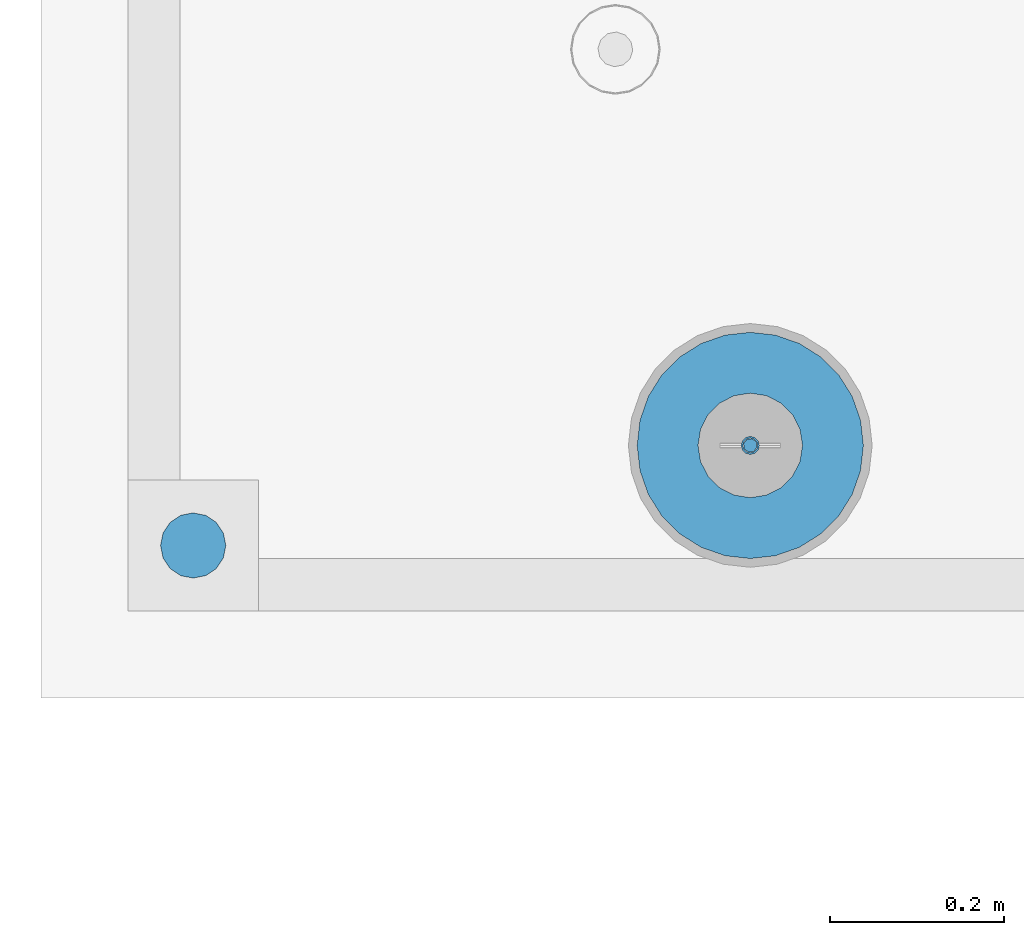
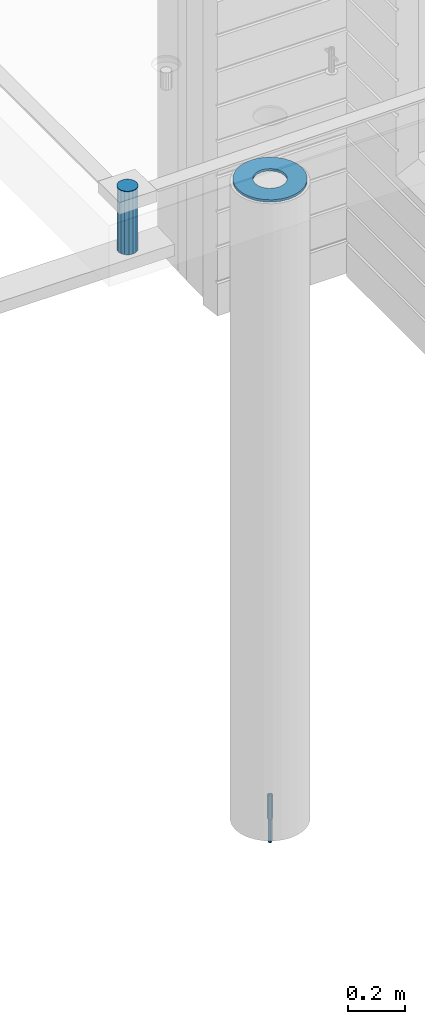
# One storey, part 8 of 350: 4 columns, 4 elements without a shape of their own.
"""IFC2X3 building model written with IfcOpenShell, lengths in millimetres."""

from ifc_helpers import new_model, si_unit, frame, origin_with_axes, place, context, subcontext, project, spatial, faceted_brep, material, type_object, element, aggregate, save


model = new_model("IFC2X3")

# Units and contexts
model_context = context("Model", 3, precision=1e-05, world=origin_with_axes())
body_context = subcontext(model_context, "Body", "Model", "MODEL_VIEW")
ifc_project = project(units=[si_unit("LENGTHUNIT", "METRE", prefix="MILLI"), si_unit("AREAUNIT", "SQUARE_METRE"), si_unit("VOLUMEUNIT", "CUBIC_METRE"), si_unit("MASSUNIT", "GRAM", prefix="KILO"), si_unit("TIMEUNIT", "SECOND"), si_unit("PLANEANGLEUNIT", "RADIAN"), si_unit("SOLIDANGLEUNIT", "STERADIAN"), si_unit("THERMODYNAMICTEMPERATUREUNIT", "DEGREE_CELSIUS"), si_unit("LUMINOUSINTENSITYUNIT", "LUMEN")], contexts=[model_context])

# Site, building, storey
site_placement = place(None, origin_with_axes())
site = spatial("IfcSite", under=ifc_project, at=site_placement, CompositionType="ELEMENT")
building_placement = place(site_placement, origin_with_axes())
building = spatial("IfcBuilding", under=site, at=building_placement, CompositionType="ELEMENT")
storey_placement = place(building_placement, origin_with_axes())
storey = spatial("IfcBuildingStorey", under=building, at=storey_placement, Name="2", CompositionType="ELEMENT", Elevation=0.0)

# Assembly, column
assembly_1_placement = place(storey_placement, origin_with_axes())
assembly_1 = element("IfcElementAssembly", 1, at=assembly_1_placement, inside=storey, AssemblyPlace="NOTDEFINED", PredefinedType="REINFORCEMENT_UNIT")
ifc_material_1 = material()
column_type_1 = type_object("IfcColumnType", Name="D75", PredefinedType="NOTDEFINED")
column_1_placement = place(assembly_1_placement, frame((7209.98489066622, 7834.99985681325, 87440.0), z_axis=(-0.000100006999999935, 0.9999999949993, 0.0), x_axis=(0.0, 0.0, 1.0)))
column_1 = element("IfcColumn", 2, at=column_1_placement, type_object=column_type_1, material=ifc_material_1, ObjectType="D75", context=body_context, shape_type="Brep", body=[
    faceted_brep([(0.0, -37.4999999999991, 1.81898940354586e-12), (0.0, -34.6454824691718, -14.3506287136888), (270.0, -34.6454824691718, -14.3506287136888), (270.0, -37.4999999999991, 1.81898940354586e-12), (0.0, -26.5165042944936, -26.5165042944936), (270.0, -26.5165042944936, -26.5165042944936), (0.0, -14.3506287136906, -34.6454824691718), (270.0, -14.3506287136906, -34.6454824691718), (0.0, 9.09494701772928e-13, -37.4999999999982), (270.0, 9.09494701772928e-13, -37.4999999999982), (0.0, 14.3506287136915, -34.6454824691718), (270.0, 14.3506287136915, -34.6454824691718), (0.0, 26.5165042944973, -26.5165042944927), (270.0, 26.5165042944973, -26.5165042944927), (0.0, 34.6454824691746, -14.3506287136897), (270.0, 34.6454824691746, -14.3506287136897), (0.0, 37.5000000000018, 1.81898940354586e-12), (270.0, 37.5000000000018, 1.81898940354586e-12), (0.0, 34.6454824691755, 14.3506287136925), (270.0, 34.6454824691755, 14.3506287136925), (0.0, 26.5165042944964, 26.5165042944973), (270.0, 26.5165042944964, 26.5165042944973), (0.0, 14.3506287136934, 34.6454824691755), (270.0, 14.3506287136934, 34.6454824691755), (0.0, 1.81898940354586e-12, 37.5000000000027), (270.0, 1.81898940354586e-12, 37.5000000000027), (0.0, -14.3506287136897, 34.6454824691746), (270.0, -14.3506287136897, 34.6454824691746), (0.0, -26.5165042944946, 26.5165042944973), (270.0, -26.5165042944946, 26.5165042944973), (0.0, -34.6454824691718, 14.3506287136925), (270.0, -34.6454824691718, 14.3506287136925)], [[[0, 1, 2, 3]], [[1, 4, 5, 2]], [[4, 6, 7, 5]], [[6, 8, 9, 7]], [[8, 10, 11, 9]], [[10, 12, 13, 11]], [[12, 14, 15, 13]], [[14, 16, 17, 15]], [[16, 18, 19, 17]], [[18, 20, 21, 19]], [[20, 22, 23, 21]], [[22, 24, 25, 23]], [[24, 26, 27, 25]], [[26, 28, 29, 27]], [[28, 30, 31, 29]], [[30, 0, 3, 31]], [[5, 7, 9, 11, 13, 15, 17, 19, 21, 23, 25, 27, 29, 31, 3, 2]], [[30, 28, 26, 24, 22, 20, 18, 16, 14, 12, 10, 8, 6, 4, 1, 0]]]),
])
aggregate(assembly_1, [column_1])

# Assemblies, columns
assembly_2_placement = place(storey_placement, origin_with_axes())
assembly_2 = element("IfcElementAssembly", 3, at=assembly_2_placement, inside=storey, AssemblyPlace="NOTDEFINED", PredefinedType="REINFORCEMENT_UNIT")
assembly_3_placement = place(assembly_2_placement, origin_with_axes())
assembly_3 = element("IfcElementAssembly", 4, at=assembly_3_placement, Name="Steel Assembly", AssemblyPlace="NOTDEFINED", PredefinedType="RIGID_FRAME")
ifc_material_2 = material(Name="STEEL/S235JR")
column_type_2 = type_object("IfcColumnType", Name="D16", PredefinedType="NOTDEFINED")
column_2_placement = place(assembly_3_placement, frame((7850.00048014349, 7949.98420120467, 84625.0), z_axis=(-0.261346946111888, -0.96524492941325, 0.0), x_axis=(0.0, 0.0, 1.0)))
column_2 = element("IfcColumn", 5, at=column_2_placement, type_object=column_type_2, material=ifc_material_2, Name="M16", ObjectType="D16", context=body_context, shape_type="Brep", body=[
    faceted_brep([(0.0, -8.0, 0.0), (0.0, -5.65685424949334, -5.65685424949334), (150.0, -5.65685424949697, -5.65685424949334), (150.0, -8.00000000000364, 0.0), (0.0, 0.0, -8.0), (150.0, -7.27595761418343e-12, -7.99999999999636), (0.0, 5.65685424949334, -5.65685424949334), (150.0, 5.6568542494897, -5.65685424949334), (0.0, 8.0, 0.0), (150.0, 8.0, -3.63797880709171e-12), (0.0, 5.65685424949334, 5.65685424949334), (150.0, 5.65685424949334, 5.65685424949697), (0.0, 0.0, 8.0), (150.0, -3.63797880709171e-12, 8.0), (0.0, -5.65685424949334, 5.65685424949334), (150.0, -5.65685424949334, 5.6568542494897)], [[[0, 1, 2, 3]], [[1, 4, 5, 2]], [[4, 6, 7, 5]], [[6, 8, 9, 7]], [[8, 10, 11, 9]], [[10, 12, 13, 11]], [[12, 14, 15, 13]], [[14, 0, 3, 15]], [[5, 7, 9, 11, 13, 15, 3, 2]], [[14, 12, 10, 8, 6, 4, 1, 0]]]),
])
aggregate(assembly_3, [column_2])
assembly_4_placement = place(assembly_2_placement, origin_with_axes())
assembly_4 = element("IfcElementAssembly", 6, at=assembly_4_placement, Name="Steel Assembly", AssemblyPlace="NOTDEFINED", PredefinedType="RIGID_FRAME")
ifc_material_3 = material(Name="STEEL/Steel_Undefined")
column_type_3 = type_object("IfcColumnType", PredefinedType="NOTDEFINED")
column_3_placement = place(assembly_4_placement, frame((7849.99879520436, 7949.98488883804, 84725.0), z_axis=(0.0, 1.0, 0.0), x_axis=(0.0, 0.0, 1.0)))
column_3 = element("IfcColumn", 7, at=column_3_placement, type_object=column_type_3, material=ifc_material_3, context=body_context, shape_type="Brep", body=[
    faceted_brep([(0.0, -8.49999999999272, -1.45519152283669e-11), (0.0, -7.36121593215648, 4.24999999998545), (100.000000000262, -7.36121593215648, 4.24999999998545), (100.000000000262, -8.49999999999272, -1.45519152283669e-11), (0.0, -4.24999999998545, 7.36121593216376), (100.000000000262, -4.24999999998545, 7.36121593216376), (0.0, 1.45519152283669e-11, 8.49999999998545), (100.000000000262, 1.45519152283669e-11, 8.49999999998545), (0.0, 4.25000000001455, 7.36121593216376), (100.000000000262, 4.25000000001455, 7.36121593216376), (0.0, 7.36121593217104, 4.24999999998545), (100.000000000262, 7.36121593217104, 4.24999999998545), (0.0, 8.50000000000728, 0.0), (100.000000000262, 8.50000000000728, 0.0), (0.0, 7.36121593217104, -4.25000000001455), (100.000000000262, 7.36121593217104, -4.25000000001455), (0.0, 4.25000000000728, -7.36121593219286), (100.000000000262, 4.25000000000728, -7.36121593219286), (0.0, 7.27595761418343e-12, -8.5), (100.000000000262, 7.27595761418343e-12, -8.5), (0.0, -4.24999999999272, -7.36121593217831), (100.000000000262, -4.24999999999272, -7.36121593217831), (0.0, -7.36121593215648, -4.25), (100.000000000262, -7.36121593215648, -4.25), (0.0, -10.4999999999927, -1.45519152283669e-11), (0.0, -9.09326673972828, -5.25000000001455), (100.000000000262, -9.09326673972828, -5.25000000001455), (100.000000000262, -10.4999999999927, -1.45519152283669e-11), (0.0, -5.24999999998545, -9.09326673974283), (100.000000000262, -5.24999999998545, -9.09326673974283), (0.0, 7.27595761418343e-12, -10.5), (100.000000000262, 7.27595761418343e-12, -10.5), (0.0, 5.25000000001455, -9.09326673975738), (100.000000000262, 5.25000000001455, -9.09326673975738), (0.0, 9.09326673975011, -5.25000000001455), (100.000000000262, 9.09326673975011, -5.25000000001455), (0.0, 10.5000000000073, -1.45519152283669e-11), (100.000000000262, 10.5000000000073, -1.45519152283669e-11), (0.0, 9.09326673975011, 5.25), (100.000000000262, 9.09326673975011, 5.25), (0.0, 5.25000000000728, 9.09326673972828), (100.000000000262, 5.25000000000728, 9.09326673972828), (0.0, 1.45519152283669e-11, 10.4999999999854), (100.000000000262, 1.45519152283669e-11, 10.4999999999854), (0.0, -5.24999999999272, 9.09326673972828), (100.000000000262, -5.24999999999272, 9.09326673972828), (0.0, -9.09326673972828, 5.24999999998545), (100.000000000262, -9.09326673972828, 5.24999999998545)], [[[0, 1, 2, 3]], [[1, 4, 5, 2]], [[4, 6, 7, 5]], [[6, 8, 9, 7]], [[8, 10, 11, 9]], [[10, 12, 13, 11]], [[12, 14, 15, 13]], [[14, 16, 17, 15]], [[16, 18, 19, 17]], [[18, 20, 21, 19]], [[20, 22, 23, 21]], [[22, 0, 3, 23]], [[24, 25, 26, 27]], [[25, 28, 29, 26]], [[28, 30, 31, 29]], [[30, 32, 33, 31]], [[32, 34, 35, 33]], [[34, 36, 37, 35]], [[36, 38, 39, 37]], [[38, 40, 41, 39]], [[40, 42, 43, 41]], [[42, 44, 45, 43]], [[44, 46, 47, 45]], [[46, 24, 27, 47]], [[29, 31, 33, 35, 37, 39, 41, 43, 45, 47, 27, 26], [5, 7, 9, 11, 13, 15, 17, 19, 21, 23, 3, 2]], [[46, 44, 42, 40, 38, 36, 34, 32, 30, 28, 25, 24], [22, 20, 18, 16, 14, 12, 10, 8, 6, 4, 1, 0]]]),
])
aggregate(assembly_4, [column_3])
ifc_material_4 = material()
column_type_4 = type_object("IfcColumnType", Name="D260", PredefinedType="NOTDEFINED")
column_4_placement = place(assembly_2_placement, frame((7849.99879520436, 7949.98488883804, 87435.0), z_axis=(-1.0, 3.00000001838171e-08, 0.0), x_axis=(0.0, 0.0, 1.0)))
column_4 = element("IfcColumn", 8, at=column_4_placement, type_object=column_type_4, material=ifc_material_4, Name="60", ObjectType="D260", context=body_context, shape_type="Brep", body=[
    faceted_brep([(10.0, -18.541019662498, -57.0633909777098), (0.0, -18.541019662498, -57.0633909777098), (0.0, -35.2671151375471, -48.5410196624944), (10.0, -35.2671151375471, -48.5410196624944), (0.0, -48.541019662498, -35.2671151375471), (10.0, -48.541019662498, -35.2671151375471), (0.0, -57.0633909777098, -18.5410196624944), (10.0, -57.0633909777098, -18.5410196624944), (0.0, -60.0, 0.0), (10.0, -60.0, 0.0), (0.0, -57.0633909777098, 18.5410196624944), (10.0, -57.0633909777098, 18.5410196624944), (0.0, -48.541019662498, 35.2671151375471), (10.0, -48.541019662498, 35.2671151375471), (0.0, -35.2671151375471, 48.5410196624944), (10.0, -35.2671151375471, 48.5410196624944), (0.0, -18.541019662498, 57.0633909777098), (10.0, -18.541019662498, 57.0633909777098), (0.0, 0.0, 60.0), (10.0, 0.0, 60.0), (0.0, 18.541019662498, 57.0633909777098), (10.0, 18.541019662498, 57.0633909777098), (0.0, 35.2671151375471, 48.5410196624944), (10.0, 35.2671151375471, 48.5410196624944), (0.0, 48.541019662498, 35.2671151375471), (10.0, 48.541019662498, 35.2671151375471), (0.0, 57.0633909777098, 18.5410196624944), (10.0, 57.0633909777098, 18.5410196624944), (0.0, 60.0, 0.0), (10.0, 60.0, 0.0), (0.0, 57.0633909777098, -18.5410196624944), (10.0, 57.0633909777098, -18.5410196624944), (0.0, 48.541019662498, -35.2671151375471), (10.0, 48.541019662498, -35.2671151375471), (0.0, 35.2671151375471, -48.5410196624944), (10.0, 35.2671151375471, -48.5410196624944), (0.0, 18.541019662498, -57.0633909777098), (10.0, 18.541019662498, -57.0633909777098), (0.0, 0.0, -60.0), (10.0, 0.0, -60.0), (0.0, -126.740628583637, -28.9277214143222), (0.0, -117.125952827315, -56.4048860852854), (10.0, -117.125952827315, -56.4048860852854), (10.0, -126.740628583637, -28.9277214143222), (0.0, -101.638092720845, -81.0536742416371), (10.0, -101.638092720845, -81.0536742416371), (0.0, -81.0536742416371, -101.638092720845), (10.0, -81.0536742416371, -101.638092720845), (0.0, -56.4048860852818, -117.125952827315), (10.0, -56.4048860852818, -117.125952827315), (0.0, -28.9277214143222, -126.740628583641), (10.0, -28.9277214143222, -126.740628583641), (0.0, 0.0, -130.0), (10.0, 0.0, -130.0), (0.0, 28.9277214143222, -126.740628583641), (10.0, 28.9277214143222, -126.740628583641), (0.0, 56.4048860852818, -117.125952827315), (10.0, 56.4048860852818, -117.125952827315), (0.0, 81.0536742416371, -101.638092720845), (10.0, 81.0536742416371, -101.638092720845), (0.0, 101.638092720845, -81.0536742416371), (10.0, 101.638092720845, -81.0536742416371), (0.0, 117.125952827315, -56.4048860852854), (10.0, 117.125952827315, -56.4048860852854), (0.0, 126.740628583637, -28.9277214143222), (10.0, 126.740628583637, -28.9277214143222), (0.0, 130.0, -1.81898940354586e-12), (10.0, 130.0, 0.0), (0.0, 126.740628583637, 28.9277214143222), (10.0, 126.740628583637, 28.9277214143222), (0.0, 117.125952827315, 56.4048860852854), (10.0, 117.125952827315, 56.4048860852854), (0.0, 101.638092720845, 81.0536742416371), (10.0, 101.638092720845, 81.0536742416371), (0.0, 81.0536742416371, 101.638092720845), (10.0, 81.0536742416371, 101.638092720845), (0.0, 56.4048860852818, 117.125952827315), (10.0, 56.4048860852818, 117.125952827315), (0.0, 28.9277214143222, 126.740628583641), (10.0, 28.9277214143222, 126.740628583641), (0.0, 0.0, 130.0), (10.0, 0.0, 130.0), (0.0, -28.9277214143222, 126.740628583641), (10.0, -28.9277214143222, 126.740628583641), (0.0, -56.4048860852818, 117.125952827315), (10.0, -56.4048860852818, 117.125952827315), (0.0, -81.0536742416371, 101.638092720845), (10.0, -81.0536742416371, 101.638092720845), (0.0, -101.638092720845, 81.0536742416371), (10.0, -101.638092720845, 81.0536742416371), (0.0, -117.125952827315, 56.4048860852854), (10.0, -117.125952827315, 56.4048860852854), (0.0, -126.740628583637, 28.9277214143222), (10.0, -126.740628583637, 28.9277214143222), (0.0, -130.0, -3.63797880709171e-12), (10.0, -130.0, 0.0)], [[[0, 1, 2, 3]], [[3, 2, 4, 5]], [[5, 4, 6, 7]], [[7, 6, 8, 9]], [[9, 8, 10, 11]], [[11, 10, 12, 13]], [[13, 12, 14, 15]], [[15, 14, 16, 17]], [[17, 16, 18, 19]], [[19, 18, 20, 21]], [[21, 20, 22, 23]], [[23, 22, 24, 25]], [[25, 24, 26, 27]], [[27, 26, 28, 29]], [[29, 28, 30, 31]], [[31, 30, 32, 33]], [[33, 32, 34, 35]], [[35, 34, 36, 37]], [[37, 36, 38, 39]], [[39, 38, 1, 0]], [[40, 41, 42, 43]], [[41, 44, 45, 42]], [[44, 46, 47, 45]], [[46, 48, 49, 47]], [[48, 50, 51, 49]], [[50, 52, 53, 51]], [[52, 54, 55, 53]], [[54, 56, 57, 55]], [[56, 58, 59, 57]], [[58, 60, 61, 59]], [[60, 62, 63, 61]], [[62, 64, 65, 63]], [[64, 66, 67, 65]], [[66, 68, 69, 67]], [[68, 70, 71, 69]], [[70, 72, 73, 71]], [[72, 74, 75, 73]], [[74, 76, 77, 75]], [[76, 78, 79, 77]], [[78, 80, 81, 79]], [[80, 82, 83, 81]], [[82, 84, 85, 83]], [[84, 86, 87, 85]], [[86, 88, 89, 87]], [[88, 90, 91, 89]], [[90, 92, 93, 91]], [[92, 94, 95, 93]], [[42, 45, 47, 49, 51, 53, 55, 57, 59, 61, 63, 65, 67, 69, 71, 73, 75, 77, 79, 81, 83, 85, 87, 89, 91, 93, 95, 43], [3, 5, 7, 9, 11, 13, 15, 17, 19, 21, 23, 25, 27, 29, 31, 33, 35, 37, 39, 0]], [[94, 40, 43, 95]], [[92, 90, 88, 86, 84, 82, 80, 78, 76, 74, 72, 70, 68, 66, 64, 62, 60, 58, 56, 54, 52, 50, 48, 46, 44, 41, 40, 94], [34, 32, 30, 28, 26, 24, 22, 20, 18, 16, 14, 12, 10, 8, 6, 4, 2, 1, 38, 36]]]),
])
aggregate(assembly_2, [assembly_4, assembly_3, column_4])

save(model, "model.ifc")
